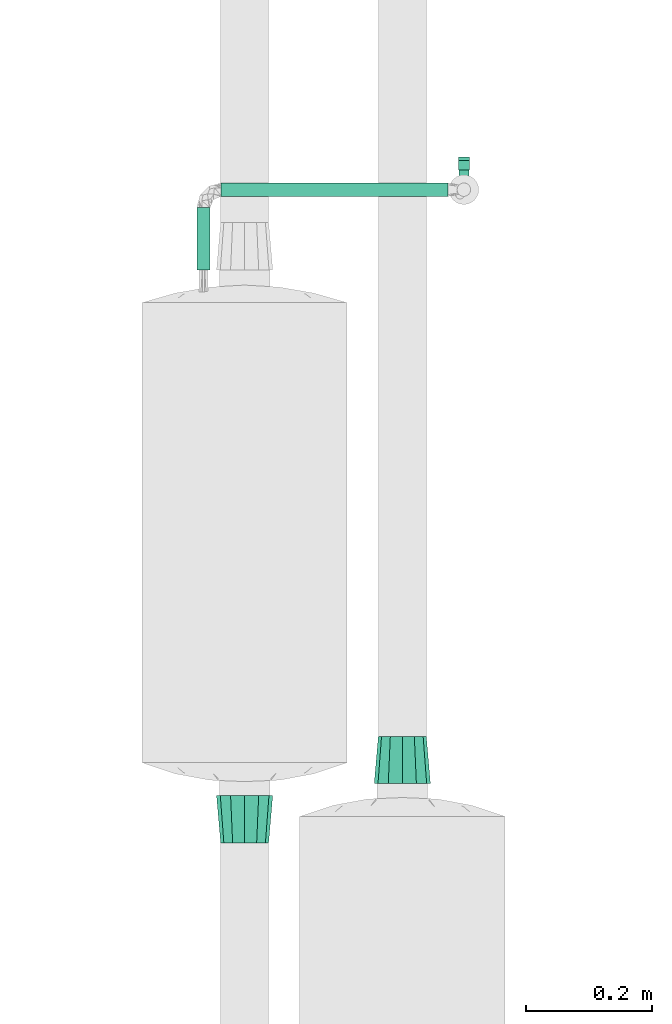
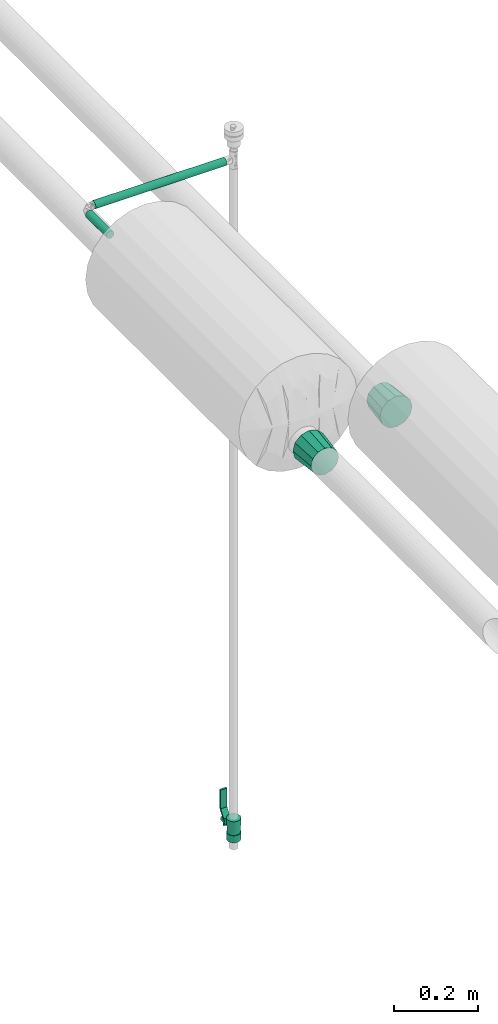
# One storey, part 590 of 827: 2 flow fittings, 2 flow segments, 1 flow controller.
"""IFC2X3 building model written with IfcOpenShell, lengths in millimetres."""

from ifc_helpers import new_model, entity, si_unit, converted_unit, derived_unit, direction, frame, origin, origin_2d_with_axis, place, context, subcontext, project, spatial, polyline, circle, outline, extrude, faceted_brep, source, transform, mapped, material, material_list, type_object, type_shapes, element, save


model = new_model("IFC2X3")

# Units and contexts
model_context = context("Model", 3, precision=0.01, world=origin(), true_north=direction((6.12303176911189e-17, 1.0)))
body_context = subcontext(model_context, "Body", "Model", "MODEL_VIEW")
ifc_project = project(units=[si_unit("LENGTHUNIT", "METRE", prefix="MILLI"), si_unit("AREAUNIT", "SQUARE_METRE"), si_unit("VOLUMEUNIT", "CUBIC_METRE"), converted_unit("PLANEANGLEUNIT", "DEGREE", entity("IfcRatioMeasure", 0.0174532925199433), si_unit("PLANEANGLEUNIT", "RADIAN"), dimensions=[0, 0, 0, 0, 0, 0, 0]), si_unit("MASSUNIT", "GRAM", prefix="KILO"), derived_unit("MASSDENSITYUNIT", [(si_unit("MASSUNIT", "GRAM", prefix="KILO"), 1), (si_unit("LENGTHUNIT", "METRE"), -3)]), derived_unit("MOMENTOFINERTIAUNIT", [(si_unit("LENGTHUNIT", "METRE"), 4)]), si_unit("TIMEUNIT", "SECOND"), si_unit("FREQUENCYUNIT", "HERTZ"), si_unit("THERMODYNAMICTEMPERATUREUNIT", "DEGREE_CELSIUS"), derived_unit("THERMALTRANSMITTANCEUNIT", [(si_unit("MASSUNIT", "GRAM", prefix="KILO"), 1), (si_unit("THERMODYNAMICTEMPERATUREUNIT", "KELVIN"), -1), (si_unit("TIMEUNIT", "SECOND"), -3)]), derived_unit("VOLUMETRICFLOWRATEUNIT", [(si_unit("LENGTHUNIT", "METRE"), 3), (si_unit("TIMEUNIT", "SECOND"), -1)]), derived_unit("MASSFLOWRATEUNIT", [(si_unit("MASSUNIT", "GRAM", prefix="KILO"), 1), (si_unit("TIMEUNIT", "SECOND"), -1)]), derived_unit("ROTATIONALFREQUENCYUNIT", [(si_unit("TIMEUNIT", "SECOND"), -1)]), si_unit("ELECTRICCURRENTUNIT", "AMPERE"), si_unit("ELECTRICVOLTAGEUNIT", "VOLT"), si_unit("POWERUNIT", "WATT"), si_unit("FORCEUNIT", "NEWTON", prefix="KILO"), si_unit("ILLUMINANCEUNIT", "LUX"), si_unit("LUMINOUSFLUXUNIT", "LUMEN"), si_unit("LUMINOUSINTENSITYUNIT", "CANDELA"), derived_unit("USERDEFINED", [(si_unit("MASSUNIT", "GRAM", prefix="KILO"), -1), (si_unit("LENGTHUNIT", "METRE"), -2), (si_unit("TIMEUNIT", "SECOND"), 3), (si_unit("LUMINOUSFLUXUNIT", "LUMEN"), 1)]), derived_unit("LINEARVELOCITYUNIT", [(si_unit("LENGTHUNIT", "METRE"), 1), (si_unit("TIMEUNIT", "SECOND"), -1)]), si_unit("PRESSUREUNIT", "PASCAL"), derived_unit("USERDEFINED", [(si_unit("LENGTHUNIT", "METRE"), -2), (si_unit("MASSUNIT", "GRAM", prefix="KILO"), 1), (si_unit("TIMEUNIT", "SECOND"), -2)]), derived_unit("LINEARFORCEUNIT", [(si_unit("MASSUNIT", "GRAM", prefix="KILO"), 1), (si_unit("LENGTHUNIT", "METRE"), 1), (si_unit("TIMEUNIT", "SECOND"), -2), (si_unit("LENGTHUNIT", "METRE"), -1)]), derived_unit("PLANARFORCEUNIT", [(si_unit("MASSUNIT", "GRAM", prefix="KILO"), 1), (si_unit("LENGTHUNIT", "METRE"), 1), (si_unit("TIMEUNIT", "SECOND"), -2), (si_unit("LENGTHUNIT", "METRE"), -2)])], contexts=[model_context])

# Site, building, storey
site_placement = place(None, origin())
site = spatial("IfcSite", under=ifc_project, at=site_placement, CompositionType="ELEMENT")
building_placement = place(site_placement, origin())
building = spatial("IfcBuilding", under=site, at=building_placement, CompositionType="ELEMENT")
storey_placement = place(building_placement, frame((0.0, 0.0, 28200.0)))
storey = spatial("IfcBuildingStorey", under=building, at=storey_placement, Name="08", CompositionType="ELEMENT", Elevation=28200.0)

# Flow segments
pipe_segment_type = type_object("IfcPipeSegmentType", PredefinedType="NOTDEFINED")
flow_segment_1_placement = place(storey_placement, frame((25907.17, 17928.03, 3117.75)))
element("IfcFlowSegment", 1, at=flow_segment_1_placement, inside=storey, type_object=pipe_segment_type, context=body_context, shape_type="SweptSolid", body=[
    extrude(circle(Radius=10.65, at=origin_2d_with_axis()), frame((0.0, 12.25, 12.25), z_axis=(1.0, 0.0, 0.0), x_axis=(0.0, 1.0, 0.0)), (0.0, 0.0, 1.0), 359.183718234219),
])
flow_segment_2_placement = place(storey_placement, frame((25866.93, 17813.3, 3117.75)))
element("IfcFlowSegment", 2, at=flow_segment_2_placement, inside=storey, type_object=pipe_segment_type, context=body_context, shape_type="SweptSolid", body=[
    extrude(circle(Radius=10.65, at=origin_2d_with_axis()), frame((12.25, 0.0, 12.25), z_axis=(0.0, 1.0, 0.0), x_axis=(1.0, 0.0, 0.0)), (0.0, 0.0, 1.0), 98.9730688746563),
])

# Flow controller
ifc_material = material()
ifc_material_list = material_list([ifc_material, ifc_material, ifc_material, ifc_material, ifc_material])
valve_type = type_object("IfcValveType", PredefinedType="NOTDEFINED", material=ifc_material_list)
shared_shape_1 = source(origin(), body_context, "Body", "SweptSolid", [
    extrude(circle(Radius=17.5, at=origin_2d_with_axis()), frame((-30.5, 0.0, 0.0), z_axis=(1.0, 0.0, 0.0), x_axis=(0.0, 1.0, 0.0)), (0.0, 0.0, 1.0), 20.3333333333333),
    extrude(circle(Radius=16.0, at=origin_2d_with_axis()), frame((-10.17, 0.0, 0.0), z_axis=(1.0, 0.0, 0.0), x_axis=(0.0, 1.0, 0.0)), (0.0, 0.0, 1.0), 20.3333333333333),
    extrude(circle(Radius=17.5, at=origin_2d_with_axis()), frame((10.17, 0.0, 0.0), z_axis=(1.0, 0.0, 0.0), x_axis=(0.0, 1.0, 0.0)), (0.0, 0.0, 1.0), 20.3333333333333),
    extrude(outline(polyline([(-38.75, -5.0), (-38.75, -10.0), (-17.92, -10.0), (2.08, 5.0), (56.25, 5.0), (56.25, 10.0), (0.42, 10.0), (-19.58, -5.0), (-38.75, -5.0)])), frame((28.75, -8.75, 41.5), z_axis=(0.0, -1.0, 0.0), x_axis=(1.0, 0.0, 0.0)), (0.0, 0.0, -1.0), 17.5),
    extrude(circle(Radius=8.0, at=origin_2d_with_axis()), origin(), (0.0, 0.0, 1.0), 49.0),
])
type_shapes(valve_type, [shared_shape_1])
flow_controller_placement = place(storey_placement, frame((26291.36, 17940.27, 1188.33), z_axis=(0.0, 1.0, 0.0), x_axis=(0.0, 0.0, 1.0)))
element("IfcFlowController", 3, at=flow_controller_placement, inside=storey, type_object=valve_type, material=ifc_material_list, context=body_context, shape_type="MappedRepresentation", body=[
    mapped(shared_shape_1, transform((0.0, 0.0, 0.0), scale=1.0)),
])

# Flow fittings
pipe_fitting_type_1 = type_object("IfcPipeFittingType", Name="ADSK_2", PredefinedType="NOTDEFINED", material=ifc_material)
shared_shape_2 = source(origin(), body_context, "Body", "Brep", [
    faceted_brep([(75.0, 32.91, 19.0), (75.0, 25.95, 25.95), (75.0, 19.0, 32.91), (75.0, 9.5, 35.45), (75.0, 0.0, 38.0), (75.0, -9.5, 35.45), (75.0, -19.0, 32.91), (75.0, -25.95, 25.95), (75.0, -32.91, 19.0), (75.0, -35.45, 9.5), (75.0, -38.0, 0.0), (75.0, -35.45, -9.5), (75.0, -32.91, -19.0), (75.0, -25.95, -25.95), (75.0, -19.0, -32.91), (75.0, -9.5, -35.45), (75.0, 0.0, -38.0), (75.0, 9.5, -35.45), (75.0, 19.0, -32.91), (75.0, 25.95, -25.95), (75.0, 32.91, -19.0), (75.0, 35.45, -9.5), (75.0, 38.0, 0.0), (75.0, 35.45, 9.5), (0.0, 11.12, 41.52), (0.0, 22.25, 38.54), (0.0, 30.39, 30.39), (0.0, 38.54, 22.25), (0.0, 41.52, 11.12), (0.0, 44.5, 0.0), (0.0, 41.52, -11.13), (0.0, 38.54, -22.25), (0.0, 30.39, -30.39), (0.0, 22.25, -38.54), (0.0, 11.12, -41.52), (0.0, 0.0, -44.5), (0.0, -11.13, -41.52), (0.0, -22.25, -38.54), (0.0, -30.39, -30.39), (0.0, -38.54, -22.25), (0.0, -41.52, -11.12), (0.0, -44.5, 0.0), (0.0, -41.52, 11.13), (0.0, -38.54, 22.25), (0.0, -30.39, 30.39), (0.0, -22.25, 38.54), (0.0, -11.12, 41.52), (0.0, 0.0, 44.5)], [[[0, 1, 2, 3, 4, 5, 6, 7, 8, 9, 10, 11, 12, 13, 14, 15, 16, 17, 18, 19, 20, 21, 22, 23]], [[24, 25, 26, 27, 28, 29, 30, 31, 32, 33, 34, 35, 36, 37, 38, 39, 40, 41, 42, 43, 44, 45, 46, 47]], [[21, 20, 31, 30, 29, 22]], [[34, 33, 18, 17, 16, 35]], [[33, 32, 31, 20, 19, 18]], [[36, 35, 16, 15, 14, 37]], [[10, 41, 40, 39, 12, 11]], [[12, 39, 38, 37, 14, 13]], [[9, 8, 43, 42, 41, 10]], [[46, 45, 6, 5, 4, 47]], [[45, 44, 43, 8, 7, 6]], [[24, 47, 4, 3, 2, 25]], [[22, 29, 28, 27, 0, 23]], [[0, 27, 26, 25, 2, 1]]]),
])
type_shapes(pipe_fitting_type_1, [shared_shape_2])
flow_fitting_1_placement = place(storey_placement, frame((25944.29, 16981.3, 3000.0), z_axis=(0.0, 0.0, 1.0), x_axis=(0.0, -1.0, 0.0)))
element("IfcFlowFitting", 4, at=flow_fitting_1_placement, inside=storey, type_object=pipe_fitting_type_1, material=ifc_material, Name="ADSK_2", ObjectType="ADSK_2", context=body_context, shape_type="MappedRepresentation", body=[
    mapped(shared_shape_2, transform((0.0, 0.0, 0.0), scale=1.0)),
])
pipe_fitting_type_2 = type_object("IfcPipeFittingType", Name="ADSK_2", PredefinedType="NOTDEFINED", material=ifc_material)
shared_shape_3 = source(origin(), body_context, "Body", "Brep", [
    faceted_brep([(75.0, -44.5, 0.0), (75.0, -41.54, -11.05), (75.0, -38.54, -22.25), (75.0, -30.39, -30.39), (75.0, -22.25, -38.54), (75.0, -11.13, -41.52), (75.0, 0.0, -44.5), (75.0, 11.12, -41.52), (75.0, 22.25, -38.54), (75.0, 30.39, -30.39), (75.0, 38.54, -22.25), (75.0, 41.54, -11.05), (75.0, 44.5, 0.0), (75.0, 41.54, 11.05), (75.0, 38.54, 22.25), (75.0, 30.39, 30.39), (75.0, 22.25, 38.54), (75.0, 11.12, 41.52), (75.0, 0.0, 44.5), (75.0, -11.13, 41.52), (75.0, -22.25, 38.54), (75.0, -30.39, 30.39), (75.0, -38.54, 22.25), (75.0, -41.54, 11.05), (0.0, -32.91, -19.0), (0.0, -35.45, -9.5), (0.0, -38.0, 0.0), (0.0, -35.45, 9.5), (0.0, -32.91, 19.0), (0.0, -25.95, 25.95), (0.0, -19.0, 32.91), (0.0, -9.5, 35.45), (0.0, 0.0, 38.0), (0.0, 9.5, 35.45), (0.0, 19.0, 32.91), (0.0, 25.95, 25.95), (0.0, 32.91, 19.0), (0.0, 35.45, 9.5), (0.0, 38.0, 0.0), (0.0, 35.45, -9.5), (0.0, 32.91, -19.0), (0.0, 25.95, -25.95), (0.0, 19.0, -32.91), (0.0, 9.5, -35.45), (0.0, 0.0, -38.0), (0.0, -9.5, -35.45), (0.0, -19.0, -32.91), (0.0, -25.95, -25.95)], [[[0, 1, 2, 3, 4, 5, 6, 7, 8, 9, 10, 11, 12, 13, 14, 15, 16, 17, 18, 19, 20, 21, 22, 23]], [[24, 25, 26, 27, 28, 29, 30, 31, 32, 33, 34, 35, 36, 37, 38, 39, 40, 41, 42, 43, 44, 45, 46, 47]], [[24, 47, 46, 4, 3, 2]], [[42, 8, 7, 6, 44, 43]], [[10, 40, 39, 38, 12, 11]], [[44, 6, 5, 4, 46, 45]], [[2, 1, 0, 26, 25, 24]], [[9, 8, 42, 41, 40, 10]], [[36, 35, 34, 16, 15, 14]], [[30, 20, 19, 18, 32, 31]], [[22, 28, 27, 26, 0, 23]], [[32, 18, 17, 16, 34, 33]], [[14, 13, 12, 38, 37, 36]], [[21, 20, 30, 29, 28, 22]]]),
])
type_shapes(pipe_fitting_type_2, [shared_shape_3])
flow_fitting_2_placement = place(storey_placement, frame((26193.91, 17075.0, 3000.0), z_axis=(0.0, 0.0, 1.0), x_axis=(0.0, -1.0, 0.0)))
element("IfcFlowFitting", 5, at=flow_fitting_2_placement, inside=storey, type_object=pipe_fitting_type_2, material=ifc_material, Name="ADSK_2", ObjectType="ADSK_2", context=body_context, shape_type="MappedRepresentation", body=[
    mapped(shared_shape_3, transform((0.0, 0.0, 0.0), scale=1.0)),
])

save(model, "model.ifc")
